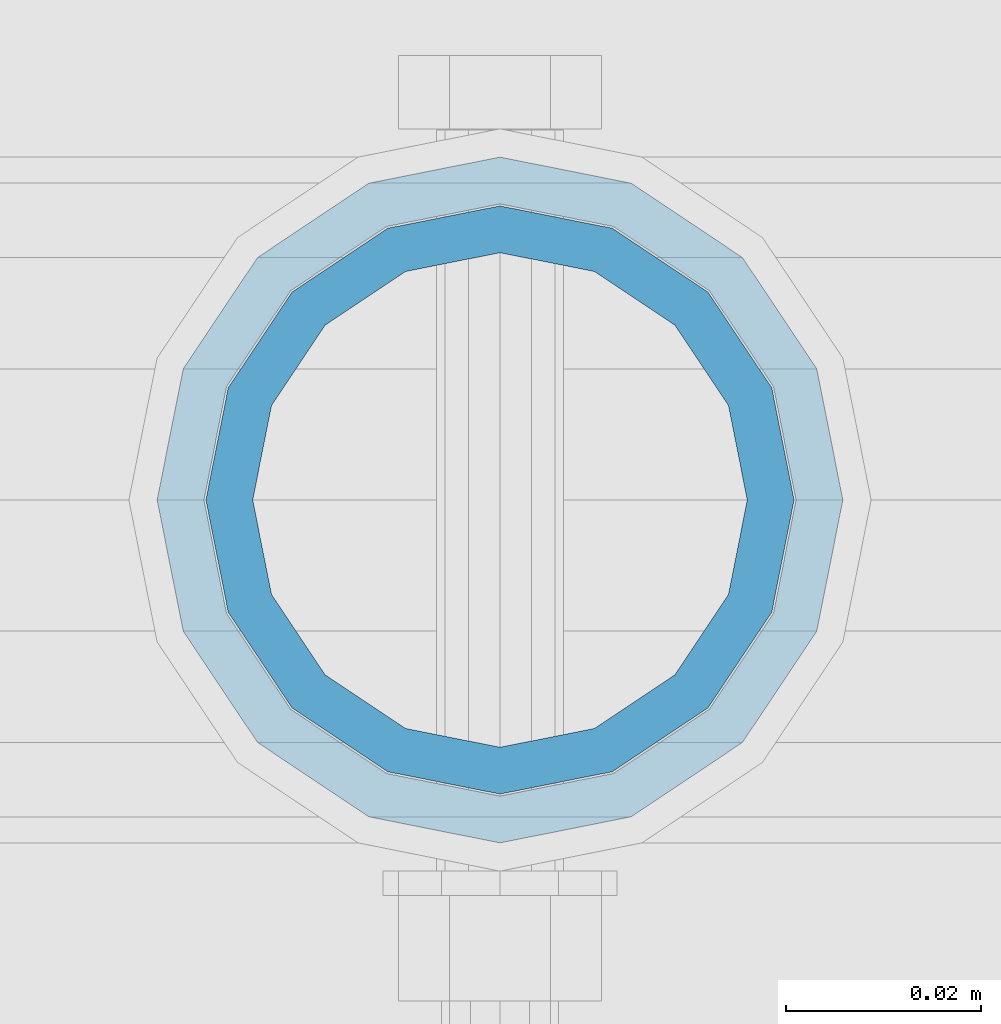
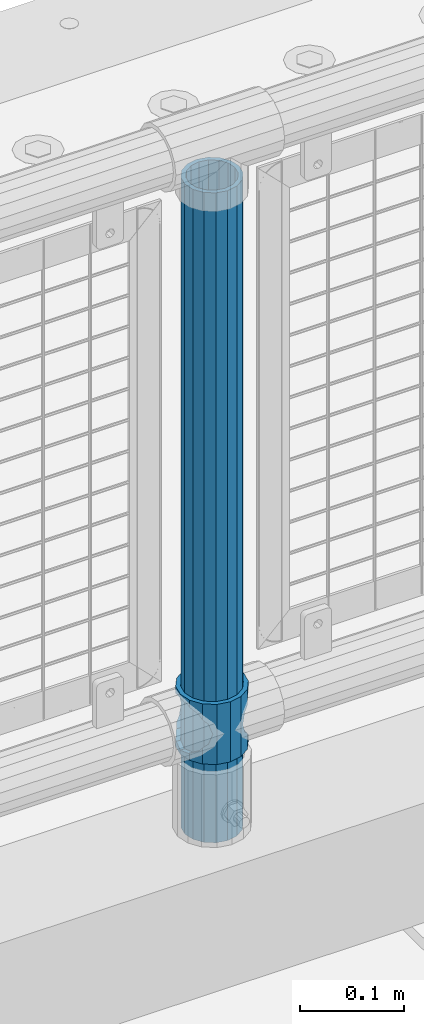
# One storey, part 69 of 240: 2 columns.
"""IFC2X3 building model written with IfcOpenShell, lengths in millimetres."""

from ifc_helpers import new_model, si_unit, frame, origin_with_axes, place, context, subcontext, project, spatial, faceted_brep, material, type_object, element, save


model = new_model("IFC2X3")

# Units and contexts
model_context = context("Model", 3, precision=1e-05, world=origin_with_axes())
body_context = subcontext(model_context, "Body", "Model", "MODEL_VIEW")
ifc_project = project(units=[si_unit("LENGTHUNIT", "METRE", prefix="MILLI"), si_unit("AREAUNIT", "SQUARE_METRE"), si_unit("VOLUMEUNIT", "CUBIC_METRE"), si_unit("MASSUNIT", "GRAM", prefix="KILO"), si_unit("TIMEUNIT", "SECOND"), si_unit("PLANEANGLEUNIT", "RADIAN"), si_unit("SOLIDANGLEUNIT", "STERADIAN"), si_unit("THERMODYNAMICTEMPERATUREUNIT", "DEGREE_CELSIUS"), si_unit("LUMINOUSINTENSITYUNIT", "LUMEN")], contexts=[model_context])

# Site, building, storey
site_placement = place(None, origin_with_axes())
site = spatial("IfcSite", under=ifc_project, at=site_placement, CompositionType="ELEMENT")
building_placement = place(site_placement, origin_with_axes())
building = spatial("IfcBuilding", under=site, at=building_placement, Name="Standard", CompositionType="ELEMENT")
storey_placement = place(building_placement, origin_with_axes())
storey = spatial("IfcBuildingStorey", under=building, at=storey_placement, Name="Undefined", CompositionType="ELEMENT", Elevation=0.0)

# Columns
ifc_material_1 = material(Name="Misc_Undefined")
column_type_1 = type_object("IfcColumnType", PredefinedType="NOTDEFINED")
column_1_placement = place(storey_placement, frame((44729.0, 34664.5, 263.02), z_axis=(-1.0, 0.0, 0.0), x_axis=(0.0, 0.0, 1.0)))
element("IfcColumn", 1, at=column_1_placement, inside=storey, type_object=column_type_1, material=ifc_material_1, context=body_context, shape_type="Brep", body=[
    faceted_brep([(56.6106908090114, 21.4606908090136, -21.4606908090136), (56.6106908090114, 21.4606908090136, -27.1226768591077), (61.9623795176703, 13.4513226476338, -32.4743655677739), (63.1897438117172, 11.6144421722784, -32.8397438117172), (63.1897438117172, 11.6144421722784, -28.0397438117143), (46.7644421722801, 28.0397438117143, -11.6144421722784), (46.7644421722801, 28.0397438117143, -20.0882031229849), (51.5310424079941, 24.8548033587067, -24.8548033587067), (35.1500000000015, 30.35, 0.0), (35.1499999999996, 30.3499999999985, -16.6306603983685), (23.5355578277192, 28.0397438117143, -11.6144421722784), (23.5355578277192, 28.0397438117143, -20.0882031229849), (13.6893091909879, 21.4606908090136, -21.4606908090136), (13.6893091909879, 21.4606908090136, -27.1226768591077), (18.7689575919921, 24.8548033587067, -24.8548033587067), (7.11025618828211, 11.6144421722784, -28.0397438117143), (7.11025618828211, 11.6144421722784, -32.8397438117172), (8.33762048232893, 13.4513226476338, -32.4743655677739), (4.79999999999961, 0.0, -30.3499999999985), (4.79999999999961, 0.0, -35.1500000000015), (7.11025618828211, -11.6144421722784, -28.0397438117143), (7.11025618828211, -11.6144421722784, -32.8397438117245), (13.6893091909879, -21.4606908090136, -21.4606908090136), (13.6893091909879, -21.4606908090136, -27.1226768591223), (8.33762048232455, -13.4513226476338, -32.4743655677739), (23.5355578277191, -28.0397438117143, -11.6144421722784), (23.5355578277191, -28.0397438117143, -20.0882031229994), (18.7689575919987, -24.8548033587067, -24.8548033587067), (35.1500000000015, -30.35, 0.0), (35.1499999999996, -30.3499999999985, -16.6306603983758), (46.7644421722801, -28.0397438117143, -11.6144421722784), (46.7644421722801, -28.0397438117143, -20.0882031229994), (56.6106908090114, -21.4606908090136, -21.4606908090136), (56.6106908090114, -21.4606908090136, -27.1226768591223), (51.5310424080006, -24.8548033587067, -24.8548033587067), (63.1897438117172, -11.6144421722784, -28.0397438117143), (63.1897438117172, -11.6144421722784, -32.8397438117245), (61.9623795176703, -13.4513226476338, -32.4743655677739), (65.4999999999997, 0.0, -30.3499999999985), (65.4999999999997, 0.0, -35.1500000000015), (0.0, -28.0397438117143, -11.6144421722784), (0.0, -30.3499999999985, 0.0), (0.0, -21.4606908090136, -21.4606908090136), (0.0, -11.6144421722784, -28.0397438117143), (0.0, 0.0, -30.3499999999985), (0.0, 11.6144421722784, -28.0397438117143), (0.0, 21.4606908090136, -21.4606908090136), (0.0, 28.0397438117143, -11.6144421722784), (0.0, 30.3499999999985, 0.0), (0.0, 28.0397438117143, 11.6144421722784), (23.5355578277192, 28.0397438117143, 11.6144421722784), (0.0, 21.4606908090136, 21.4606908090136), (13.6893091909879, 21.4606908090136, 21.4606908090136), (0.0, 11.6144421722784, 28.0397438117143), (7.11025618828211, 11.6144421722784, 28.0397438117143), (0.0, 0.0, 30.3499999999985), (4.79999999999961, 0.0, 30.3499999999985), (0.0, -11.6144421722784, 28.0397438117143), (7.11025618828205, -11.6144421722784, 28.0397438117143), (0.0, -21.4606908090136, 21.4606908090136), (13.6893091909879, -21.4606908090136, 21.4606908090136), (0.0, -28.0397438117143, 11.6144421722784), (23.5355578277191, -28.0397438117143, 11.6144421722784), (0.0, -32.4743655677739, 13.4513226476338), (0.0, -35.1500000000015, 0.0), (70.2999999999993, -35.1500000000015, 0.0), (70.2999999999993, -32.4743655677739, 13.4513226476338), (0.0, 13.4513226476338, -32.4743655677739), (0.0, 24.8548033587067, -24.8548033587067), (0.0, 0.0, -35.1500000000015), (0.0, -13.4513226476338, -32.4743655677739), (0.0, -24.8548033587067, -24.8548033587067), (0.0, -24.8548033587067, 24.8548033587067), (0.0, -13.4513226476338, 32.4743655677739), (0.0, 0.0, 35.1500000000015), (0.0, 13.4513226476338, 32.4743655677739), (0.0, 24.8548033587067, 24.8548033587067), (0.0, 32.4743655677739, 13.4513226476338), (0.0, 35.1500000000015, 0.0), (0.0, 32.4743655677739, -13.4513226476338), (0.0, -32.4743655677739, -13.4513226476338), (70.2999999999993, 32.4743655677739, 13.4513226476338), (70.2999999999993, 35.1500000000015, 0.0), (70.2999999999993, 32.4743655677739, -13.4513226476338), (70.2999999999993, 24.8548033587067, -24.8548033587067), (70.2999999999993, 13.4513226476338, -32.4743655677739), (70.2999999999993, 0.0, -35.1500000000015), (70.2999999999993, -13.4513226476338, -32.4743655677739), (70.2999999999993, -24.8548033587067, -24.8548033587067), (70.2999999999993, -32.4743655677739, -13.4513226476338), (70.2999999999993, 28.0397438117143, 11.6144421722784), (70.2999999999993, 21.4606908090136, 21.4606908090136), (56.6106908090114, 21.4606908090136, 21.4606908090136), (46.7644421722801, 28.0397438117143, 11.6144421722784), (70.2999999999993, 11.6144421722784, 28.0397438117143), (63.1897438117172, 11.6144421722784, 28.0397438117143), (70.2999999999993, 0.0, 30.3499999999985), (65.4999999999997, 0.0, 30.3499999999985), (70.2999999999993, -11.6144421722784, 28.0397438117143), (63.1897438117172, -11.6144421722784, 28.0397438117143), (70.2999999999993, -21.4606908090136, 21.4606908090136), (56.6106908090114, -21.4606908090136, 21.4606908090136), (70.2999999999993, -28.0397438117143, 11.6144421722784), (46.7644421722801, -28.0397438117143, 11.6144421722784), (70.2999999999993, -11.6144421722784, -28.0397438117143), (70.2999999999993, 0.0, -30.3499999999985), (70.2999999999993, -21.4606908090136, -21.4606908090136), (70.2999999999993, -28.0397438117143, -11.6144421722784), (70.2999999999993, -30.3499999999985, 0.0), (70.2999999999993, 24.8548033587067, 24.8548033587067), (70.2999999999993, 13.4513226476338, 32.4743655677739), (70.2999999999993, 0.0, 35.1500000000015), (70.2999999999993, -13.4513226476338, 32.4743655677739), (70.2999999999993, -24.8548033587067, 24.8548033587067), (70.2999999999993, 30.3499999999985, 0.0), (70.2999999999993, 28.0397438117143, -11.6144421722784), (70.2999999999993, 21.4606908090136, -21.4606908090136), (70.2999999999993, 11.6144421722784, -28.0397438117143), (61.9623795176742, 13.4513226476338, 32.4743655677739), (51.5310424079941, 24.8548033587067, 24.8548033587067), (56.6106908090114, 21.4606908090136, 27.1226768591077), (65.4999999999997, 0.0, 35.1500000000015), (63.1897438117172, 11.6144421722784, 32.8397438117172), (63.1897438117172, -11.6144421722784, 32.8397438117172), (61.9623795176698, -13.4513226476338, 32.4743655677739), (56.6106908090114, -21.4606908090136, 27.1226768591005), (51.5310424080006, -24.8548033587067, 24.8548033587067), (18.7689575919987, -24.8548033587067, 24.8548033587067), (46.7644421722801, -28.0397438117143, 20.0882031229994), (35.1499999999996, -30.3499999999985, 16.6306603983758), (23.5355578277191, -28.0397438117143, 20.0882031229994), (8.33762048232506, -13.4513226476338, 32.4743655677739), (13.6893091909879, -21.4606908090136, 27.1226768591005), (4.79999999999961, 0.0, 35.1500000000015), (7.11025618828205, -11.6144421722784, 32.8397438117172), (7.11025618828211, 11.6144421722784, 32.8397438117172), (8.33762048232506, 13.4513226476338, 32.4743655677739), (13.6893091909879, 21.4606908090136, 27.1226768591077), (18.7689575919856, 24.8548033587067, 24.8548033587067), (23.5355578277192, 28.0397438117143, 20.0882031229994), (35.1499999999996, 30.3499999999985, 16.6306603983758), (46.7644421722801, 28.0397438117143, 20.0882031229994)], [[[0, 1, 2, 3, 4]], [[5, 6, 7, 1, 0]], [[8, 9, 6, 5]], [[10, 11, 9, 8]], [[12, 13, 14, 11, 10]], [[15, 16, 17, 13, 12]], [[18, 19, 16, 15]], [[20, 21, 19, 18]], [[22, 23, 24, 21, 20]], [[25, 26, 27, 23, 22]], [[28, 29, 26, 25]], [[30, 31, 29, 28]], [[32, 33, 34, 31, 30]], [[35, 36, 37, 33, 32]], [[38, 39, 36, 35]], [[4, 3, 39, 38]], [[40, 41, 28, 25]], [[42, 40, 25, 22]], [[43, 42, 22, 20]], [[44, 43, 20, 18]], [[45, 44, 18, 15]], [[46, 45, 15, 12]], [[47, 46, 12, 10]], [[48, 47, 10, 8]], [[49, 48, 8, 50]], [[51, 49, 50, 52]], [[53, 51, 52, 54]], [[55, 53, 54, 56]], [[57, 55, 56, 58]], [[59, 57, 58, 60]], [[61, 59, 60, 62]], [[41, 61, 62, 28]], [[63, 64, 65, 66]], [[17, 67, 68, 14, 13]], [[19, 69, 67, 17, 16]], [[70, 69, 19, 21, 24]], [[71, 70, 24, 23, 27]], [[63, 72, 73, 74, 75, 76, 77, 78, 79, 68, 67, 69, 70, 71, 80, 64], [40, 42, 43, 44, 45, 46, 47, 48, 49, 51, 53, 55, 57, 59, 61, 41]], [[78, 77, 81, 82]], [[79, 78, 82, 83]], [[14, 68, 79, 83, 84, 7, 6, 9, 11]], [[84, 85, 2, 1, 7]], [[85, 86, 39, 3, 2]], [[37, 87, 88, 34, 33]], [[39, 86, 87, 37, 36]], [[34, 88, 89, 80, 71, 27, 26, 29, 31]], [[64, 80, 89, 65]], [[90, 91, 92, 93]], [[91, 94, 95, 92]], [[94, 96, 97, 95]], [[96, 98, 99, 97]], [[98, 100, 101, 99]], [[100, 102, 103, 101]], [[104, 105, 38, 35]], [[106, 104, 35, 32]], [[107, 106, 32, 30]], [[108, 107, 30, 28]], [[102, 108, 28, 103]], [[88, 87, 86, 85, 84, 83, 82, 81, 109, 110, 111, 112, 113, 66, 65, 89], [100, 98, 96, 94, 91, 90, 114, 115, 116, 117, 105, 104, 106, 107, 108, 102]], [[118, 110, 109, 119, 120]], [[121, 111, 110, 118, 122]], [[112, 111, 121, 123, 124]], [[113, 112, 124, 125, 126]], [[127, 72, 63, 66, 113, 126, 128, 129, 130]], [[131, 73, 72, 127, 132]], [[133, 74, 73, 131, 134]], [[75, 74, 133, 135, 136]], [[76, 75, 136, 137, 138]], [[119, 109, 81, 77, 76, 138, 139, 140, 141]], [[92, 120, 119, 141, 93]], [[95, 122, 118, 120, 92]], [[97, 121, 122, 95]], [[99, 123, 121, 97]], [[101, 125, 124, 123, 99]], [[103, 128, 126, 125, 101]], [[28, 129, 128, 103]], [[62, 130, 129, 28]], [[60, 132, 127, 130, 62]], [[58, 134, 131, 132, 60]], [[56, 133, 134, 58]], [[54, 135, 133, 56]], [[52, 137, 136, 135, 54]], [[50, 139, 138, 137, 52]], [[8, 140, 139, 50]], [[93, 141, 140, 8]], [[114, 90, 93, 8]], [[115, 114, 8, 5]], [[116, 115, 5, 0]], [[117, 116, 0, 4]], [[105, 117, 4, 38]]]),
])
ifc_material_2 = material()
column_type_2 = type_object("IfcColumnType", PredefinedType="NOTDEFINED")
column_2_placement = place(storey_placement, frame((44729.0, 34664.5, 168.02), z_axis=(-1.0, 0.0, 0.0), x_axis=(0.0, 0.0, 1.0)))
element("IfcColumn", 2, at=column_2_placement, inside=storey, type_object=column_type_2, material=ifc_material_2, context=body_context, shape_type="Brep", body=[
    faceted_brep([(0.0, -25.3499999999985, 0.0), (0.0, -23.4203461491634, 9.70102501045767), (760.0, -23.4203461491634, 9.70102501045767), (760.0, -25.3499999999985, 0.0), (0.0, -17.9251569030821, 17.9251569030821), (760.0, -17.9251569030821, 17.9251569030821), (0.0, -9.70102501045767, 23.4203461491634), (760.0, -9.70102501045767, 23.4203461491634), (0.0, 0.0, 25.3499999999985), (760.0, 0.0, 25.3499999999985), (0.0, 9.70102501045767, 23.4203461491634), (760.0, 9.70102501045767, 23.4203461491634), (0.0, 17.9251569030821, 17.9251569030821), (760.0, 17.9251569030821, 17.9251569030821), (0.0, 23.4203461491634, 9.70102501045767), (760.0, 23.4203461491634, 9.70102501045767), (0.0, 25.3499999999985, 0.0), (760.0, 25.3499999999985, 0.0), (0.0, 23.4203461491634, -9.70102501045767), (760.0, 23.4203461491634, -9.70102501045767), (0.0, 17.9251569030821, -17.9251569030821), (760.0, 17.9251569030821, -17.9251569030821), (0.0, 9.70102501045767, -23.4203461491634), (760.0, 9.70102501045767, -23.4203461491634), (0.0, 0.0, -25.3499999999985), (760.0, 0.0, -25.3499999999985), (0.0, -9.70102501045767, -23.4203461491634), (760.0, -9.70102501045767, -23.4203461491634), (0.0, -17.9251569030821, -17.9251569030821), (760.0, -17.9251569030821, -17.9251569030821), (0.0, -23.4203461491634, -9.70102501045767), (760.0, -23.4203461491634, -9.70102501045767), (0.0, -30.1500000000015, 0.0), (0.0, -27.8549679052157, -11.5379054858058), (760.0, -27.8549679052157, -11.5379054858058), (760.0, -30.1500000000015, 0.0), (0.0, -21.3192694527752, -21.3192694527752), (760.0, -21.3192694527752, -21.3192694527752), (0.0, -11.5379054858058, -27.8549679052157), (760.0, -11.5379054858058, -27.8549679052157), (0.0, 0.0, -30.1500000000015), (760.0, 0.0, -30.1500000000015), (0.0, 11.5379054858058, -27.8549679052157), (760.0, 11.5379054858058, -27.8549679052157), (0.0, 21.3192694527752, -21.3192694527752), (760.0, 21.3192694527752, -21.3192694527752), (0.0, 27.8549679052157, -11.5379054858058), (760.0, 27.8549679052157, -11.5379054858058), (0.0, 30.1500000000015, 0.0), (760.0, 30.1500000000015, 0.0), (0.0, 27.8549679052157, 11.5379054858058), (760.0, 27.8549679052157, 11.5379054858058), (0.0, 21.3192694527752, 21.3192694527752), (760.0, 21.3192694527752, 21.3192694527752), (0.0, 11.5379054858058, 27.8549679052157), (760.0, 11.5379054858058, 27.8549679052157), (0.0, 0.0, 30.1500000000015), (760.0, 0.0, 30.1500000000015), (0.0, -11.5379054858058, 27.8549679052157), (760.0, -11.5379054858058, 27.8549679052157), (0.0, -21.3192694527752, 21.3192694527752), (760.0, -21.3192694527752, 21.3192694527752), (0.0, -27.8549679052157, 11.5379054858058), (760.0, -27.8549679052157, 11.5379054858058)], [[[0, 1, 2, 3]], [[1, 4, 5, 2]], [[4, 6, 7, 5]], [[6, 8, 9, 7]], [[8, 10, 11, 9]], [[10, 12, 13, 11]], [[12, 14, 15, 13]], [[14, 16, 17, 15]], [[16, 18, 19, 17]], [[18, 20, 21, 19]], [[20, 22, 23, 21]], [[22, 24, 25, 23]], [[24, 26, 27, 25]], [[26, 28, 29, 27]], [[28, 30, 31, 29]], [[30, 0, 3, 31]], [[32, 33, 34, 35]], [[33, 36, 37, 34]], [[36, 38, 39, 37]], [[38, 40, 41, 39]], [[40, 42, 43, 41]], [[42, 44, 45, 43]], [[44, 46, 47, 45]], [[46, 48, 49, 47]], [[48, 50, 51, 49]], [[50, 52, 53, 51]], [[52, 54, 55, 53]], [[54, 56, 57, 55]], [[56, 58, 59, 57]], [[58, 60, 61, 59]], [[60, 62, 63, 61]], [[62, 32, 35, 63]], [[37, 39, 41, 43, 45, 47, 49, 51, 53, 55, 57, 59, 61, 63, 35, 34], [5, 7, 9, 11, 13, 15, 17, 19, 21, 23, 25, 27, 29, 31, 3, 2]], [[62, 60, 58, 56, 54, 52, 50, 48, 46, 44, 42, 40, 38, 36, 33, 32], [30, 28, 26, 24, 22, 20, 18, 16, 14, 12, 10, 8, 6, 4, 1, 0]]]),
])

save(model, "model.ifc")
